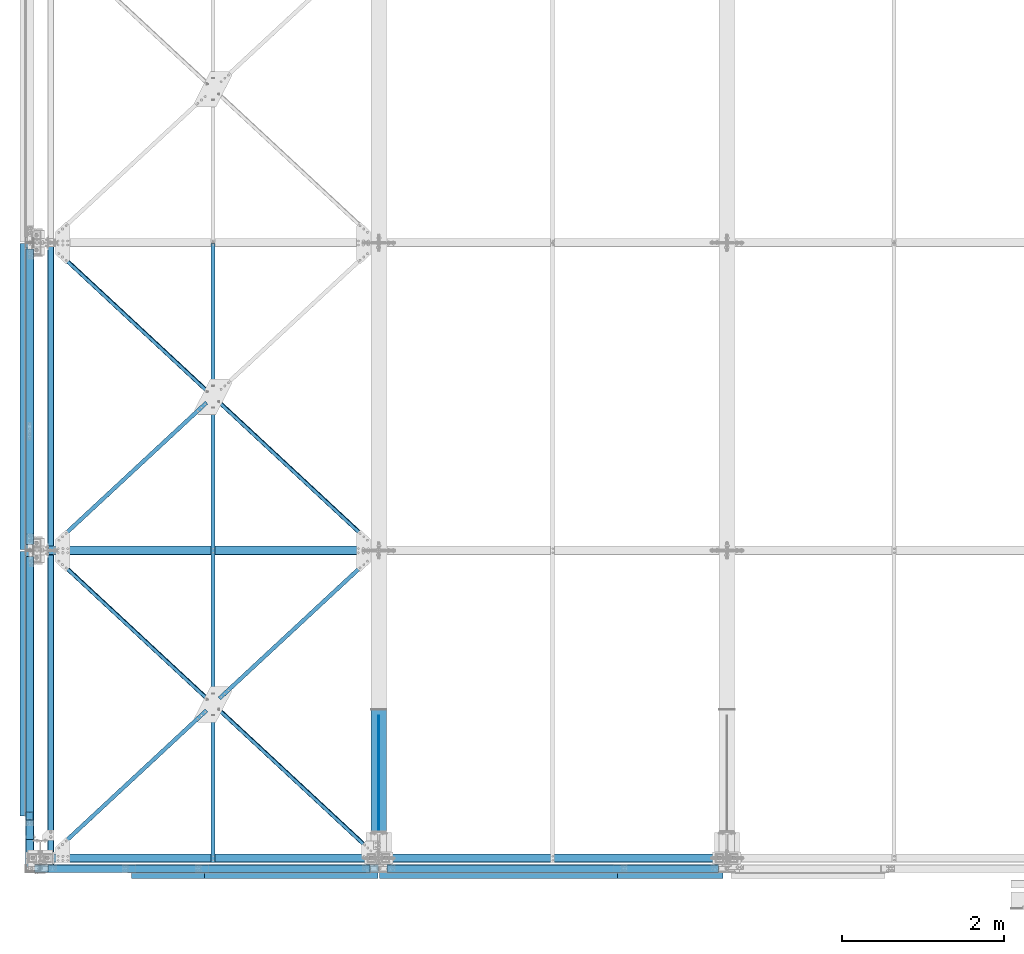
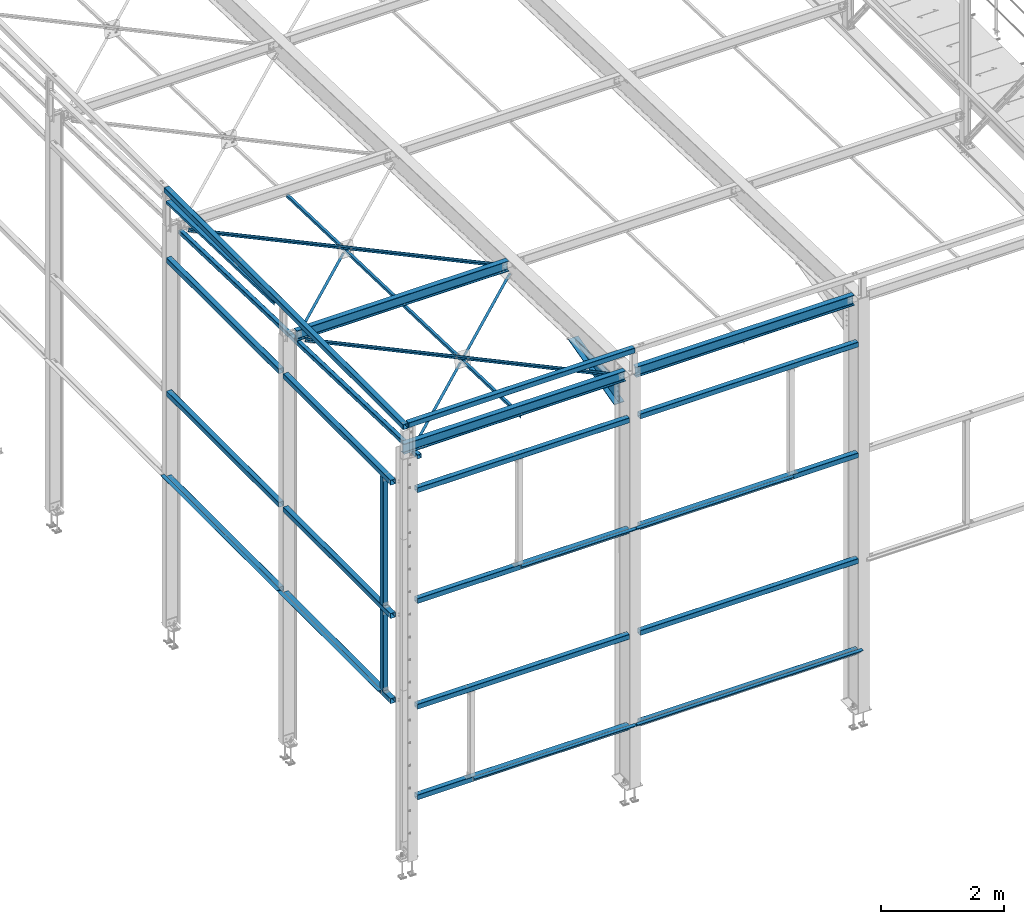
# One storey, part 41 of 496: 37 beams, 30 elements without a shape of their own.
"""IFC2X3 building model written with IfcOpenShell, lengths in millimetres."""

from ifc_helpers import new_model, si_unit, frame, origin_with_axes, origin_2d_with_axis, place, context, subcontext, project, spatial, polyline, rectangle, hollow_rectangle, i_section, l_section, u_section, outline, extrude, clip, halfspace, material, type_object, element, aggregate, save


model = new_model("IFC2X3")

# Units and contexts
model_context = context("Model", 3, precision=1e-05, world=origin_with_axes())
body_context = subcontext(model_context, "Body", "Model", "MODEL_VIEW")
ifc_project = project(units=[si_unit("LENGTHUNIT", "METRE", prefix="MILLI"), si_unit("AREAUNIT", "SQUARE_METRE"), si_unit("VOLUMEUNIT", "CUBIC_METRE"), si_unit("MASSUNIT", "GRAM", prefix="KILO"), si_unit("TIMEUNIT", "SECOND"), si_unit("PLANEANGLEUNIT", "RADIAN"), si_unit("SOLIDANGLEUNIT", "STERADIAN"), si_unit("THERMODYNAMICTEMPERATUREUNIT", "DEGREE_CELSIUS"), si_unit("LUMINOUSINTENSITYUNIT", "LUMEN")], contexts=[model_context])

# Site, building, storey
site_placement = place(None, origin_with_axes())
site = spatial("IfcSite", under=ifc_project, at=site_placement, CompositionType="ELEMENT")
building_placement = place(site_placement, origin_with_axes())
building = spatial("IfcBuilding", under=site, at=building_placement, Name="Undefined", CompositionType="ELEMENT")
storey_placement = place(building_placement, origin_with_axes())
storey = spatial("IfcBuildingStorey", under=building, at=storey_placement, Name="Undefined", CompositionType="ELEMENT", Elevation=0.0)

# Assembly, beam
assembly_1_placement = place(storey_placement, origin_with_axes())
assembly_1 = element("IfcElementAssembly", 1, at=assembly_1_placement, inside=storey, AssemblyPlace="NOTDEFINED", PredefinedType="NOTDEFINED")
ifc_material_1 = material(Name="Undefined/S235-E24")
beam_type_1 = type_object("IfcBeamType", PredefinedType="NOTDEFINED")
beam_1_placement = place(assembly_1_placement, frame((2132.95777562896, 1898.08608063122, 7759.23296372596), z_axis=(0.680838347690318, -0.732072290870568, 0.0230066349959325), x_axis=(0.732433713070062, 0.680502369065094, -0.0213864830020458)))
beam_1 = element("IfcBeam", 2, at=beam_1_placement, type_object=beam_type_1, material=ifc_material_1, context=body_context, shape_type="Clipping", body=[
    clip(clip(extrude(l_section(Depth=50.0, Width=50.0, Thickness=5.0, FilletRadius=7.0, EdgeRadius=3.5, at=origin_2d_with_axis()), frame((2792.06114197264, 9.68690801868511e-15, -2.64775642512471e-13), z_axis=(-1.0, 0.0, 0.0), x_axis=(0.0, -1.0, 0.0)), (0.0, 0.0, 1.0), 2736.72), halfspace(frame((2629.60111589512, 24.9999928826783, 24.9999858812455), z_axis=(1.0, 0.0, 0.0), x_axis=(0.0, 0.0, -1.0)), False)), halfspace(frame((106.894615057048, 31.0093179303303, 24.9999999768324), z_axis=(1.0, 0.0, 0.0), x_axis=(0.0, 1.0, 0.0)), True)),
])
aggregate(assembly_1, [beam_1])

assembly_2_placement = place(storey_placement, origin_with_axes())
assembly_2 = element("IfcElementAssembly", 3, at=assembly_2_placement, inside=storey, AssemblyPlace="NOTDEFINED", PredefinedType="NOTDEFINED")
beam_2_placement = place(assembly_2_placement, frame((2132.00001266682, -53.9015129067157, 7826.58977123071), z_axis=(1.0, 0.0, 0.0), x_axis=(0.0, 0.999506556345274, -0.0314108870109058)))
beam_2 = element("IfcBeam", 4, at=beam_2_placement, type_object=beam_type_1, material=ifc_material_1, context=body_context, shape_type="SweptSolid", body=[
    extrude(l_section(Depth=50.0, Width=50.0, Thickness=5.0, FilletRadius=7.0, EdgeRadius=3.5, at=origin_2d_with_axis()), frame((7648.75199419146, 0.0, 0.0), z_axis=(-1.0, 0.0, 0.0), x_axis=(0.0, -1.0, 0.0)), (0.0, 0.0, 1.0), 7648.75),
])
aggregate(assembly_2, [beam_2])

assembly_3_placement = place(storey_placement, origin_with_axes())
assembly_3 = element("IfcElementAssembly", 5, at=assembly_3_placement, inside=storey, AssemblyPlace="NOTDEFINED", PredefinedType="NOTDEFINED")
beam_3_placement = place(assembly_3_placement, frame((4182.04253757987, 3799.8493937089, 7755.49482368022), z_axis=(-0.680836493276887, -0.73207405927444, 0.023005242008624), x_axis=(-0.732435437033485, 0.680500574031111, -0.0213845580009777)))
beam_3 = element("IfcBeam", 6, at=beam_3_placement, type_object=beam_type_1, material=ifc_material_1, context=body_context, shape_type="Clipping", body=[
    clip(clip(extrude(l_section(Depth=50.0, Width=50.0, Thickness=5.0, FilletRadius=7.0, EdgeRadius=3.5, at=origin_2d_with_axis()), frame((5584.10997520641, -9.09494701772928e-13, 2.93028321659412e-13), z_axis=(-1.0, 0.0, 0.0), x_axis=(0.0, -1.0, 0.0)), (0.0, 0.0, 1.0), 5584.11), halfspace(frame((5421.64660010542, -25.0000571690553, -24.9999999506545), z_axis=(0.999999999997803, 2.09200000135276e-06, 1.31999999817392e-07), x_axis=(0.0, 0.0, 1.0)), False)), halfspace(frame((162.459932662962, 25.000057158848, -24.9999999867432), z_axis=(-0.999999999998359, -1.34631977040632e-06, 1.21235578021343e-06), x_axis=(1.21235578011417e-06, 7.45476427527536e-11, 0.999999999999265)), False)),
])
aggregate(assembly_3, [beam_3])

assembly_4_placement = place(storey_placement, origin_with_axes())
assembly_4 = element("IfcElementAssembly", 7, at=assembly_4_placement, inside=storey, AssemblyPlace="NOTDEFINED", PredefinedType="NOTDEFINED")
beam_4_placement = place(assembly_4_placement, frame((87.9574898072951, 3798.09030455743, 7699.52059346457), z_axis=(0.68083649638077, -0.732074010915111, 0.0230066889973314), x_axis=(0.732435434147601, 0.680500577137136, -0.0213845580043096)))
beam_4 = element("IfcBeam", 8, at=beam_4_placement, type_object=beam_type_1, material=ifc_material_1, context=body_context, shape_type="Clipping", body=[
    clip(clip(extrude(l_section(Depth=50.0, Width=50.0, Thickness=5.0, FilletRadius=7.0, EdgeRadius=3.5, at=origin_2d_with_axis()), frame((2736.71023834624, 8.99999830778118e-13, 4.62758648288336e-13), z_axis=(-1.0, 0.0, 0.0), x_axis=(0.0, -1.0, 0.0)), (0.0, 0.0, 1.0), 2736.71), halfspace(frame((162.463400706135, -25.0000933849551, 24.9999638658524), z_axis=(-0.999999999997803, 2.09199999990344e-06, -1.31999999818056e-07), x_axis=(-6.7626569939636e-10, 1.60677807515351e-06, -0.999999999998709)), False)), halfspace(frame((2685.15740098178, 31.0071053170741, 25.0000000625241), z_axis=(0.999999999998558, -1.69800000185205e-06, 0.0), x_axis=(1.69800000215235e-06, 0.999999999998558, 0.0)), False)),
])
aggregate(assembly_4, [beam_4])

assembly_5_placement = place(storey_placement, origin_with_axes())
assembly_5 = element("IfcElementAssembly", 9, at=assembly_5_placement, inside=storey, Name="Steel Assembly", AssemblyPlace="NOTDEFINED", PredefinedType="RIGID_FRAME")
ifc_material_2 = material(Name="STEEL/S235 --------------")
beam_5_placement = place(assembly_5_placement, frame((4182.04254313058, -0.159569882216601, 7874.91957929736), z_axis=(-0.680838342539438, -0.732071528315557, 0.0230310390099157), x_axis=(-0.732433717864216, 0.680502363873844, -0.0213864839960353)))
beam_5 = element("IfcBeam", 10, at=beam_5_placement, type_object=beam_type_1, material=ifc_material_2, context=body_context, shape_type="Clipping", body=[
    clip(clip(clip(extrude(l_section(Depth=50.0, Width=50.0, Thickness=5.0, FilletRadius=7.0, EdgeRadius=3.5, at=origin_2d_with_axis()), frame((5584.12307962439, 0.0, -2.75471486033162e-13), z_axis=(-1.0, 0.0, 0.0), x_axis=(0.0, -1.0, 0.0)), (0.0, 0.0, 1.0), 5584.12), halfspace(frame((107.352082511449, 24.9862130141391, -25.0000102419372), z_axis=(-0.999999746430007, -0.000712137375843514, -5.28847746923189e-07), x_axis=(0.0, 0.0, 1.0)), False)), halfspace(frame((3008.74022592529, 25.0624927776262, 2620.77401555206), z_axis=(0.0729183020569199, 2.43126534266734e-05, 0.997337916973997), x_axis=(3.85183070646305e-08, -0.999999999702936, 2.4374732290997e-05)), False)), halfspace(frame((5421.65924635987, -25.0005741456234, -24.9994035720497), z_axis=(1.0, 0.0, 0.0), x_axis=(7.20592651988103e-11, 2.38537934808418e-05, 0.999999999715498)), False)),
])
aggregate(assembly_5, [beam_5])

assembly_6_placement = place(storey_placement, origin_with_axes())
assembly_6 = element("IfcElementAssembly", 11, at=assembly_6_placement, inside=storey, AssemblyPlace="NOTDEFINED", PredefinedType="NOTDEFINED")
beam_6_placement = place(assembly_6_placement, frame((87.9574849970008, -1.91868095844802, 7818.94534983953), z_axis=(0.680838347690318, -0.732072290870568, 0.0230066349959325), x_axis=(0.732433713070062, 0.680502369065094, -0.0213864830020458)))
beam_6 = element("IfcBeam", 12, at=beam_6_placement, type_object=beam_type_1, material=ifc_material_1, context=body_context, shape_type="Clipping", body=[
    clip(clip(extrude(l_section(Depth=50.0, Width=50.0, Thickness=5.0, FilletRadius=7.0, EdgeRadius=3.5, at=origin_2d_with_axis()), frame((2736.72033254361, -9.09494701772928e-13, 9.38252055267922e-14), z_axis=(-1.0, 0.0, 0.0), x_axis=(0.0, -1.0, 0.0)), (0.0, 0.0, 1.0), 2736.72), halfspace(frame((162.459973877454, 25.0000221405762, -24.9999999838102), z_axis=(-1.0, 0.0, 0.0), x_axis=(0.0, 0.0, 1.0)), False)), halfspace(frame((2685.16732033268, 31.009205449107, 25.0000000845653), z_axis=(1.0, 0.0, 0.0), x_axis=(0.0, 1.0, 0.0)), False)),
])
aggregate(assembly_6, [beam_6])

assembly_7_placement = place(storey_placement, origin_with_axes())
assembly_7 = element("IfcElementAssembly", 13, at=assembly_7_placement, inside=storey, Name="LISSE", AssemblyPlace="NOTDEFINED", PredefinedType="NOTDEFINED")
beam_type_2 = type_object("IfcBeamType", PredefinedType="NOTDEFINED")
beam_7_placement = place(assembly_7_placement, frame((-129.999999999254, 3799.99999997022, 8410.85601504986), z_axis=(1.0, 0.0, 0.0), x_axis=(0.0, 0.999506445341009, -0.0314144190107172)))
beam_7 = element("IfcBeam", 14, at=beam_7_placement, type_object=beam_type_2, material=ifc_material_1, Name="LISSE", context=body_context, shape_type="Clipping", body=[
    clip(clip(extrude(u_section(Depth=100.0, FlangeWidth=50.0, WebThickness=4.0, FlangeThickness=4.0, at=origin_2d_with_axis()), frame((3738.43154409699, 2.59405798515091e-14, 0.0), z_axis=(-1.0, 0.0, 0.0), x_axis=(0.0, -1.0, 0.0)), (0.0, 0.0, 1.0), 3536.42), halfspace(frame((3735.73414698921, 35.3226290313178, 49.9999999992579), z_axis=(-0.999506472307554, -0.0314135610096736, 0.0), x_axis=(0.0, 0.0, 1.0)), True)), halfspace(frame((202.484021196273, 35.5224298009161, 49.9999999992579), z_axis=(0.999506472307554, 0.0314135610096964, 0.0), x_axis=(0.0, 0.0, 1.0)), True)),
])
aggregate(assembly_7, [beam_7])

assembly_8_placement = place(storey_placement, origin_with_axes())
assembly_8 = element("IfcElementAssembly", 15, at=assembly_8_placement, inside=storey, Name="MONTANT", AssemblyPlace="NOTDEFINED", PredefinedType="NOTDEFINED")
beam_type_3 = type_object("IfcBeamType", PredefinedType="NOTDEFINED")
beam_8_placement = place(assembly_8_placement, frame((-129.999916880554, 519.993382399492, 4445.00002208328), z_axis=(1.0, 0.0, 0.0), x_axis=(0.0, 0.0, -1.0)))
beam_8 = element("IfcBeam", 16, at=beam_8_placement, type_object=beam_type_3, material=ifc_material_1, Name="MONTANT", context=body_context, shape_type="SweptSolid", body=[
    extrude(hollow_rectangle(XDim=100.0, YDim=100.0, WallThickness=4.0, InnerFilletRadius=4.0, OuterFilletRadius=8.0, at=origin_2d_with_axis()), frame((1580.00002213783, -3.26736346536441e-22, 0.0), z_axis=(-1.0, 0.0, 0.0), x_axis=(0.0, -1.0, 0.0)), (0.0, 0.0, 1.0), 1580.0),
])
aggregate(assembly_8, [beam_8])

assembly_9_placement = place(storey_placement, origin_with_axes())
assembly_9 = element("IfcElementAssembly", 17, at=assembly_9_placement, inside=storey, Name="LISSE", AssemblyPlace="NOTDEFINED", PredefinedType="NOTDEFINED")
beam_9_placement = place(assembly_9_placement, frame((-129.999999891005, 7595.00000002971, 8500.00000001911), z_axis=(0.0, 0.0, 1.0), x_axis=(0.0, -1.0, 0.0)))
beam_9 = element("IfcBeam", 18, at=beam_9_placement, type_object=beam_type_3, material=ifc_material_1, Name="LISSE", context=body_context, shape_type="SweptSolid", body=[
    extrude(hollow_rectangle(XDim=100.0, YDim=100.0, WallThickness=4.0, InnerFilletRadius=4.0, OuterFilletRadius=8.0, at=origin_2d_with_axis()), frame((7775.00000003686, 0.0, 0.0), z_axis=(-1.0, 0.0, 0.0), x_axis=(0.0, -1.0, 0.0)), (0.0, 0.0, 1.0), 7775.0),
])
aggregate(assembly_9, [beam_9])

assembly_10_placement = place(storey_placement, origin_with_axes())
assembly_10 = element("IfcElementAssembly", 19, at=assembly_10_placement, inside=storey, Name="LISSE", AssemblyPlace="NOTDEFINED", PredefinedType="NOTDEFINED")
beam_10_placement = place(assembly_10_placement, frame((-130.000001390422, 3724.99999092642, 4500.0), z_axis=(0.0, 0.0, 1.0), x_axis=(0.0, -1.0, 0.0)))
beam_10 = element("IfcBeam", 20, at=beam_10_placement, type_object=beam_type_3, material=ifc_material_1, Name="LISSE", context=body_context, shape_type="SweptSolid", body=[
    extrude(hollow_rectangle(XDim=100.0, YDim=100.0, WallThickness=4.0, InnerFilletRadius=4.0, OuterFilletRadius=8.0, at=origin_2d_with_axis()), frame((3494.99999900398, 0.0, 0.0), z_axis=(-1.0, 0.0, 0.0), x_axis=(0.0, -1.0, 0.0)), (0.0, 0.0, 1.0), 3495.0),
])
aggregate(assembly_10, [beam_10])

assembly_11_placement = place(storey_placement, origin_with_axes())
assembly_11 = element("IfcElementAssembly", 21, at=assembly_11_placement, inside=storey, Name="LISSE", AssemblyPlace="NOTDEFINED", PredefinedType="NOTDEFINED")
beam_11_placement = place(assembly_11_placement, frame((-129.999999652064, 7524.99999131917, 4500.00000022511), z_axis=(0.0, 0.0, 1.0), x_axis=(0.0, -1.0, 0.0)))
beam_11 = element("IfcBeam", 22, at=beam_11_placement, type_object=beam_type_3, material=ifc_material_1, Name="LISSE", context=body_context, shape_type="SweptSolid", body=[
    extrude(hollow_rectangle(XDim=100.0, YDim=100.0, WallThickness=4.0, InnerFilletRadius=4.0, OuterFilletRadius=8.0, at=origin_2d_with_axis()), frame((3650.0, 0.0, 0.0), z_axis=(-1.0, 0.0, 0.0), x_axis=(0.0, -1.0, 0.0)), (0.0, 0.0, 1.0), 3650.0),
])
aggregate(assembly_11, [beam_11])

assembly_12_placement = place(storey_placement, origin_with_axes())
assembly_12 = element("IfcElementAssembly", 23, at=assembly_12_placement, inside=storey, Name="LISSE", AssemblyPlace="NOTDEFINED", PredefinedType="NOTDEFINED")
beam_12_placement = place(assembly_12_placement, frame((4285.0000000001, -130.000008279542, 7150.0), z_axis=(0.0, 0.0, -1.0), x_axis=(1.0, 0.0, 0.0)))
beam_12 = element("IfcBeam", 24, at=beam_12_placement, type_object=beam_type_3, material=ifc_material_1, Name="LISSE", context=body_context, shape_type="SweptSolid", body=[
    extrude(hollow_rectangle(XDim=100.0, YDim=100.0, WallThickness=4.0, InnerFilletRadius=4.0, OuterFilletRadius=8.0, at=origin_2d_with_axis()), frame((4089.9999999999, 0.0, 0.0), z_axis=(-1.0, 0.0, 0.0), x_axis=(0.0, -1.0, 0.0)), (0.0, 0.0, 1.0), 4090.0),
])
aggregate(assembly_12, [beam_12])

assembly_13_placement = place(storey_placement, origin_with_axes())
assembly_13 = element("IfcElementAssembly", 25, at=assembly_13_placement, inside=storey, Name="LISSE", AssemblyPlace="NOTDEFINED", PredefinedType="NOTDEFINED")
beam_13_placement = place(assembly_13_placement, frame((4285.0, -130.000008279766, 4949.99999999904), z_axis=(0.0, 0.0, 1.0), x_axis=(1.0, 0.0, 0.0)))
beam_13 = element("IfcBeam", 26, at=beam_13_placement, type_object=beam_type_3, material=ifc_material_1, Name="LISSE", context=body_context, shape_type="SweptSolid", body=[
    extrude(hollow_rectangle(XDim=100.0, YDim=100.0, WallThickness=4.0, InnerFilletRadius=4.0, OuterFilletRadius=8.0, at=origin_2d_with_axis()), frame((4089.9999999999, 0.0, 0.0), z_axis=(-1.0, 0.0, 0.0), x_axis=(0.0, -1.0, 0.0)), (0.0, 0.0, 1.0), 4090.0),
])

assembly_14_placement = place(storey_placement, origin_with_axes())
assembly_14 = element("IfcElementAssembly", 27, at=assembly_14_placement, inside=storey, Name="LISSE", AssemblyPlace="NOTDEFINED", PredefinedType="NOTDEFINED")
beam_14_placement = place(assembly_14_placement, frame((4284.99999999743, -130.000008283344, 2850.0), z_axis=(0.0, 0.0, -1.0), x_axis=(1.0, 0.0, 0.0)))
beam_14 = element("IfcBeam", 28, at=beam_14_placement, type_object=beam_type_3, material=ifc_material_1, Name="LISSE", context=body_context, shape_type="SweptSolid", body=[
    extrude(hollow_rectangle(XDim=100.0, YDim=100.0, WallThickness=4.0, InnerFilletRadius=4.0, OuterFilletRadius=8.0, at=origin_2d_with_axis()), frame((4089.9999999999, 0.0, 0.0), z_axis=(-1.0, 0.0, 0.0), x_axis=(0.0, -1.0, 0.0)), (0.0, 0.0, 1.0), 4090.0),
])
aggregate(assembly_14, [beam_14])

assembly_15_placement = place(storey_placement, origin_with_axes())
assembly_15 = element("IfcElementAssembly", 29, at=assembly_15_placement, inside=storey, Name="LISSE", AssemblyPlace="NOTDEFINED", PredefinedType="NOTDEFINED")
beam_15_placement = place(assembly_15_placement, frame((4285.00000000001, -130.000008279691, 1049.99999999904), z_axis=(0.0, 0.0, 1.0), x_axis=(1.0, 0.0, 0.0)))
beam_15 = element("IfcBeam", 30, at=beam_15_placement, type_object=beam_type_3, material=ifc_material_1, Name="LISSE", context=body_context, shape_type="SweptSolid", body=[
    extrude(hollow_rectangle(XDim=100.0, YDim=100.0, WallThickness=4.0, InnerFilletRadius=4.0, OuterFilletRadius=8.0, at=origin_2d_with_axis()), frame((4089.9999999999, 0.0, 0.0), z_axis=(-1.0, 0.0, 0.0), x_axis=(0.0, -1.0, 0.0)), (0.0, 0.0, 1.0), 4090.0),
])

assembly_16_placement = place(storey_placement, origin_with_axes())
assembly_16 = element("IfcElementAssembly", 31, at=assembly_16_placement, inside=storey, Name="LISSE", AssemblyPlace="NOTDEFINED", PredefinedType="NOTDEFINED")
beam_16_placement = place(assembly_16_placement, frame((95.0000000074225, -130.000007684713, 7150.0), z_axis=(0.0, 0.0, -1.0), x_axis=(1.0, 0.0, 0.0)))
beam_16 = element("IfcBeam", 32, at=beam_16_placement, type_object=beam_type_3, material=ifc_material_1, Name="LISSE", context=body_context, shape_type="SweptSolid", body=[
    extrude(hollow_rectangle(XDim=100.0, YDim=100.0, WallThickness=4.0, InnerFilletRadius=4.0, OuterFilletRadius=8.0, at=origin_2d_with_axis()), frame((3980.00000000009, 0.0, 0.0), z_axis=(-1.0, 0.0, 0.0), x_axis=(0.0, -1.0, 0.0)), (0.0, 0.0, 1.0), 3980.0),
])
aggregate(assembly_16, [beam_16])

assembly_17_placement = place(storey_placement, origin_with_axes())
assembly_17 = element("IfcElementAssembly", 33, at=assembly_17_placement, inside=storey, Name="LISSE", AssemblyPlace="NOTDEFINED", PredefinedType="NOTDEFINED")
beam_17_placement = place(assembly_17_placement, frame((95.0000000074318, -130.000007684151, 4949.99999999904), z_axis=(0.0, 0.0, 1.0), x_axis=(1.0, 0.0, 0.0)))
beam_17 = element("IfcBeam", 34, at=beam_17_placement, type_object=beam_type_3, material=ifc_material_1, Name="LISSE", context=body_context, shape_type="SweptSolid", body=[
    extrude(hollow_rectangle(XDim=100.0, YDim=100.0, WallThickness=4.0, InnerFilletRadius=4.0, OuterFilletRadius=8.0, at=origin_2d_with_axis()), frame((3980.00000000009, 0.0, 0.0), z_axis=(-1.0, 0.0, 0.0), x_axis=(0.0, -1.0, 0.0)), (0.0, 0.0, 1.0), 3980.0),
])

assembly_18_placement = place(storey_placement, origin_with_axes())
assembly_18 = element("IfcElementAssembly", 35, at=assembly_18_placement, inside=storey, Name="LISSE", AssemblyPlace="NOTDEFINED", PredefinedType="NOTDEFINED")
beam_18_placement = place(assembly_18_placement, frame((95.0000000074201, -130.000007684626, 2850.0), z_axis=(0.0, 0.0, -1.0), x_axis=(1.0, 0.0, 0.0)))
beam_18 = element("IfcBeam", 36, at=beam_18_placement, type_object=beam_type_3, material=ifc_material_1, Name="LISSE", context=body_context, shape_type="SweptSolid", body=[
    extrude(hollow_rectangle(XDim=100.0, YDim=100.0, WallThickness=4.0, InnerFilletRadius=4.0, OuterFilletRadius=8.0, at=origin_2d_with_axis()), frame((3980.00000000009, 0.0, 0.0), z_axis=(-1.0, 0.0, 0.0), x_axis=(0.0, -1.0, 0.0)), (0.0, 0.0, 1.0), 3980.0),
])
aggregate(assembly_18, [beam_18])

assembly_19_placement = place(storey_placement, origin_with_axes())
assembly_19 = element("IfcElementAssembly", 37, at=assembly_19_placement, inside=storey, Name="LISSE", AssemblyPlace="NOTDEFINED", PredefinedType="NOTDEFINED")
beam_19_placement = place(assembly_19_placement, frame((95.0000000074324, -130.000007684076, 1049.99999999904), z_axis=(0.0, 0.0, 1.0), x_axis=(1.0, 0.0, 0.0)))
beam_19 = element("IfcBeam", 38, at=beam_19_placement, type_object=beam_type_3, material=ifc_material_1, Name="LISSE", context=body_context, shape_type="SweptSolid", body=[
    extrude(hollow_rectangle(XDim=100.0, YDim=100.0, WallThickness=4.0, InnerFilletRadius=4.0, OuterFilletRadius=8.0, at=origin_2d_with_axis()), frame((3980.00000000009, 0.0, 0.0), z_axis=(-1.0, 0.0, 0.0), x_axis=(0.0, -1.0, 0.0)), (0.0, 0.0, 1.0), 3980.0),
])

assembly_20_placement = place(storey_placement, origin_with_axes())
assembly_20 = element("IfcElementAssembly", 39, at=assembly_20_placement, inside=storey, Name="LISSE", AssemblyPlace="NOTDEFINED", PredefinedType="NOTDEFINED")
beam_20_placement = place(assembly_20_placement, frame((-129.999999646836, 7524.9999991069, 7150.00000925125), z_axis=(0.0, 0.0, -1.0), x_axis=(0.0, -1.0, 0.0)))
beam_20 = element("IfcBeam", 40, at=beam_20_placement, type_object=beam_type_3, material=ifc_material_1, Name="LISSE", context=body_context, shape_type="SweptSolid", body=[
    extrude(hollow_rectangle(XDim=100.0, YDim=100.0, WallThickness=4.0, InnerFilletRadius=4.0, OuterFilletRadius=8.0, at=origin_2d_with_axis()), frame((3650.0, 0.0, 0.0), z_axis=(-1.0, 0.0, 0.0), x_axis=(0.0, -1.0, 0.0)), (0.0, 0.0, 1.0), 3650.0),
])
aggregate(assembly_20, [beam_20])

assembly_21_placement = place(storey_placement, origin_with_axes())
assembly_21 = element("IfcElementAssembly", 41, at=assembly_21_placement, inside=storey, Name="LISSE", AssemblyPlace="NOTDEFINED", PredefinedType="NOTDEFINED")
beam_21_placement = place(assembly_21_placement, frame((-130.00000139915, 3725.0000040295, 7150.00000377003), z_axis=(0.0, 0.0, -1.0), x_axis=(0.0, -1.0, 0.0)))
beam_21 = element("IfcBeam", 42, at=beam_21_placement, type_object=beam_type_3, material=ifc_material_1, Name="LISSE", context=body_context, shape_type="SweptSolid", body=[
    extrude(hollow_rectangle(XDim=100.0, YDim=100.0, WallThickness=4.0, InnerFilletRadius=4.0, OuterFilletRadius=8.0, at=origin_2d_with_axis()), frame((3494.99999900398, 0.0, 0.0), z_axis=(-1.0, 0.0, 0.0), x_axis=(0.0, -1.0, 0.0)), (0.0, 0.0, 1.0), 3495.0),
])
aggregate(assembly_21, [beam_21])

assembly_22_placement = place(storey_placement, origin_with_axes())
assembly_22 = element("IfcElementAssembly", 43, at=assembly_22_placement, inside=storey, Name="LISSE", AssemblyPlace="NOTDEFINED", PredefinedType="NOTDEFINED")
beam_22_placement = place(assembly_22_placement, frame((-130.000001390422, 3724.99999861062, 2809.99999988523), z_axis=(0.0, 0.0, 1.0), x_axis=(0.0, -1.0, 0.0)))
beam_22 = element("IfcBeam", 44, at=beam_22_placement, type_object=beam_type_3, material=ifc_material_1, Name="LISSE", context=body_context, shape_type="SweptSolid", body=[
    extrude(hollow_rectangle(XDim=100.0, YDim=100.0, WallThickness=4.0, InnerFilletRadius=4.0, OuterFilletRadius=8.0, at=origin_2d_with_axis()), frame((3494.99999900398, 0.0, 0.0), z_axis=(-1.0, 0.0, 0.0), x_axis=(0.0, -1.0, 0.0)), (0.0, 0.0, 1.0), 3495.0),
])

assembly_23_placement = place(storey_placement, origin_with_axes())
assembly_23 = element("IfcElementAssembly", 45, at=assembly_23_placement, inside=storey, Name="LISSE", AssemblyPlace="NOTDEFINED", PredefinedType="NOTDEFINED")
beam_23_placement = place(assembly_23_placement, frame((-129.999999652064, 7524.99999900332, 2810.00000011033), z_axis=(0.0, 0.0, 1.0), x_axis=(0.0, -1.0, 0.0)))
beam_23 = element("IfcBeam", 46, at=beam_23_placement, type_object=beam_type_3, material=ifc_material_1, Name="LISSE", context=body_context, shape_type="SweptSolid", body=[
    extrude(hollow_rectangle(XDim=100.0, YDim=100.0, WallThickness=4.0, InnerFilletRadius=4.0, OuterFilletRadius=8.0, at=origin_2d_with_axis()), frame((3650.0, 0.0, 0.0), z_axis=(-1.0, 0.0, 0.0), x_axis=(0.0, -1.0, 0.0)), (0.0, 0.0, 1.0), 3650.0),
])

assembly_24_placement = place(storey_placement, origin_with_axes())
assembly_24 = element("IfcElementAssembly", 47, at=assembly_24_placement, inside=storey, Name="MONTANT", AssemblyPlace="NOTDEFINED", PredefinedType="NOTDEFINED")
beam_24_placement = place(assembly_24_placement, frame((-129.999916873212, 519.993384643543, 7095.00000856518), z_axis=(1.0, 0.0, 0.0), x_axis=(0.0, 0.0, -1.0)))
beam_24 = element("IfcBeam", 48, at=beam_24_placement, type_object=beam_type_3, material=ifc_material_1, Name="MONTANT", context=body_context, shape_type="SweptSolid", body=[
    extrude(hollow_rectangle(XDim=100.0, YDim=100.0, WallThickness=4.0, InnerFilletRadius=4.0, OuterFilletRadius=8.0, at=origin_2d_with_axis()), frame((2539.99998650413, 0.0, 0.0), z_axis=(-1.0, 0.0, 0.0), x_axis=(0.0, -1.0, 0.0)), (0.0, 0.0, 1.0), 2540.0),
])
aggregate(assembly_24, [beam_24])

assembly_25_placement = place(storey_placement, origin_with_axes())
assembly_25 = element("IfcElementAssembly", 49, at=assembly_25_placement, inside=storey, Name="LISSE", AssemblyPlace="NOTDEFINED", PredefinedType="NOTDEFINED")
beam_25_placement = place(assembly_25_placement, frame((-70.0, -130.0, 8500.0), z_axis=(0.0, 0.0, 1.0), x_axis=(1.0, 0.0, 0.0)))
beam_25 = element("IfcBeam", 50, at=beam_25_placement, type_object=beam_type_3, material=ifc_material_1, Name="LISSE", context=body_context, shape_type="SweptSolid", body=[
    extrude(hollow_rectangle(XDim=100.0, YDim=100.0, WallThickness=4.0, InnerFilletRadius=4.0, OuterFilletRadius=8.0, at=origin_2d_with_axis()), frame((4245.0, 0.0, 0.0), z_axis=(-1.0, 0.0, 0.0), x_axis=(0.0, -1.0, 0.0)), (0.0, 0.0, 1.0), 4245.0),
])
aggregate(assembly_25, [beam_25])

# Beam
beam_type_4 = type_object("IfcBeamType", PredefinedType="NOTDEFINED")
beam_26_placement = place(assembly_13_placement, frame((4190.0, -215.000007684151, 4965.0), z_axis=(0.0, -1.0, 0.0), x_axis=(1.0, 0.0, 0.0)))
beam_26 = element("IfcBeam", 51, at=beam_26_placement, type_object=beam_type_4, material=ifc_material_1, Name="SUPPORT", context=body_context, shape_type="SweptSolid", body=[
    extrude(l_section(Depth=70.0, Width=70.0, Thickness=7.0, FilletRadius=9.0, EdgeRadius=4.5, at=origin_2d_with_axis()), frame((2940.0025831881, 0.0, 0.0), z_axis=(-1.0, 0.0, 0.0), x_axis=(0.0, -1.0, 0.0)), (0.0, 0.0, 1.0), 2940.0),
])

aggregate(assembly_13, [beam_26, beam_13])

beam_27_placement = place(assembly_15_placement, frame((4190.0, -215.000007684151, 1065.0), z_axis=(0.0, -1.0, 0.0), x_axis=(1.0, 0.0, 0.0)))
beam_27 = element("IfcBeam", 52, at=beam_27_placement, type_object=beam_type_4, material=ifc_material_1, Name="SUPPORT", context=body_context, shape_type="SweptSolid", body=[
    extrude(l_section(Depth=70.0, Width=70.0, Thickness=7.0, FilletRadius=9.0, EdgeRadius=4.5, at=origin_2d_with_axis()), frame((4239.99781571392, 0.0, 0.0), z_axis=(-1.0, 0.0, 0.0), x_axis=(0.0, -1.0, 0.0)), (0.0, 0.0, 1.0), 4240.0),
])

aggregate(assembly_15, [beam_27, beam_15])

beam_28_placement = place(assembly_19_placement, frame((1130.0, -215.000007684151, 1065.0), z_axis=(0.0, -1.0, 0.0), x_axis=(1.0, 0.0, 0.0)))
beam_28 = element("IfcBeam", 53, at=beam_28_placement, type_object=beam_type_4, material=ifc_material_1, Name="SUPPORT", context=body_context, shape_type="SweptSolid", body=[
    extrude(l_section(Depth=70.0, Width=70.0, Thickness=7.0, FilletRadius=9.0, EdgeRadius=4.5, at=origin_2d_with_axis()), frame((3040.0, 0.0, 0.0), z_axis=(-1.0, 0.0, 0.0), x_axis=(0.0, -1.0, 0.0)), (0.0, 0.0, 1.0), 3040.0),
])

aggregate(assembly_19, [beam_28, beam_19])

beam_29_placement = place(assembly_17_placement, frame((2029.99476747419, -215.000007684151, 4965.0), z_axis=(0.0, -1.0, 0.0), x_axis=(1.0, 0.0, 0.0)))
beam_29 = element("IfcBeam", 54, at=beam_29_placement, type_object=beam_type_4, material=ifc_material_1, Name="SUPPORT", context=body_context, shape_type="SweptSolid", body=[
    extrude(l_section(Depth=70.0, Width=70.0, Thickness=7.0, FilletRadius=9.0, EdgeRadius=4.5, at=origin_2d_with_axis()), frame((2140.00523252582, 0.0, 0.0), z_axis=(-1.0, 0.0, 0.0), x_axis=(0.0, -1.0, 0.0)), (0.0, 0.0, 1.0), 2140.01),
])

aggregate(assembly_17, [beam_29, beam_17])

beam_30_placement = place(assembly_23_placement, frame((-215.000001390421, 7589.99999792678, 2824.99999059685), z_axis=(-1.0, 0.0, 0.0), x_axis=(0.0, -1.0, 0.0)))
beam_30 = element("IfcBeam", 55, at=beam_30_placement, type_object=beam_type_4, material=ifc_material_1, Name="LISSE", context=body_context, shape_type="SweptSolid", body=[
    extrude(l_section(Depth=70.0, Width=70.0, Thickness=7.0, FilletRadius=9.0, EdgeRadius=4.5, at=origin_2d_with_axis()), frame((3779.99999902119, 1.5633713573204e-21, 0.0), z_axis=(-1.0, 0.0, 0.0), x_axis=(0.0, -1.0, 0.0)), (0.0, 0.0, 1.0), 3780.0),
])

aggregate(assembly_23, [beam_30, beam_23])

beam_31_placement = place(assembly_22_placement, frame((-215.000001390421, 3789.99999864029, 2824.99999052871), z_axis=(-1.0, 0.0, 0.0), x_axis=(0.0, -1.0, 0.0)))
beam_31 = element("IfcBeam", 56, at=beam_31_placement, type_object=beam_type_4, material=ifc_material_1, Name="LISSE", context=body_context, shape_type="SweptSolid", body=[
    extrude(l_section(Depth=70.0, Width=70.0, Thickness=7.0, FilletRadius=9.0, EdgeRadius=4.5, at=origin_2d_with_axis()), frame((3270.00999900399, 0.0, -4.75664309849363e-29), z_axis=(-1.0, 0.0, 0.0), x_axis=(0.0, -1.0, 0.0)), (0.0, 0.0, 1.0), 3270.01),
])

aggregate(assembly_22, [beam_31, beam_22])

# Assembly, beams
assembly_26_placement = place(storey_placement, origin_with_axes())
assembly_26 = element("IfcElementAssembly", 57, at=assembly_26_placement, inside=storey, Name="TRAVERSE", AssemblyPlace="NOTDEFINED", PredefinedType="NOTDEFINED")
beam_type_5 = type_object("IfcBeamType", PredefinedType="NOTDEFINED")
beam_32_placement = place(assembly_26_placement, frame((4180.0, 1836.15791643143, 7534.87805845615), z_axis=(1.0, 0.0, 0.0), x_axis=(0.0, -0.967446195634957, -0.253076783904507)))
beam_32 = element("IfcBeam", 58, at=beam_32_placement, type_object=beam_type_5, material=ifc_material_1, context=body_context, shape_type="SweptSolid", body=[
    extrude(rectangle(XDim=15.0, YDim=190.0, at=origin_2d_with_axis()), frame((1549.7087562475, 0.0, 0.0), z_axis=(-1.0, 0.0, 0.0), x_axis=(0.0, -1.0, 0.0)), (0.0, 0.0, 1.0), 1549.71),
])
beam_type_6 = type_object("IfcBeamType", PredefinedType="NOTDEFINED")
beam_33_placement = place(assembly_26_placement, frame((4180.0, 335.0, 7589.25004344064), z_axis=(-1.0, 0.0, 0.0), x_axis=(0.0, 0.999506556345274, -0.0314108870109058)))
beam_33 = element("IfcBeam", 59, at=beam_33_placement, type_object=beam_type_6, material=ifc_material_1, context=body_context, shape_type="SweptSolid", body=[
    extrude(outline(polyline([(0.942322762899387, 29.9851968112687), (30.0, 0.0), (1419.99999999984, -1.22432538773864e-09), (1423.27844149021, 22.6672111163732), (42.569691038819, 430.594491876205), (12.856783834807, 409.109499234062), (0.942322762899387, 29.9851968112687)])), frame((0.0, 0.0, -5.0), z_axis=(0.0, 0.0, 1.0), x_axis=(1.0, 0.0, 0.0)), (0.0, 0.0, 1.0), 10.0),
])
aggregate(assembly_26, [beam_33, beam_32])

# Assembly, beam
assembly_27_placement = place(storey_placement, origin_with_axes())
assembly_27 = element("IfcElementAssembly", 60, at=assembly_27_placement, inside=storey, AssemblyPlace="NOTDEFINED", PredefinedType="NOTDEFINED")
beam_type_7 = type_object("IfcBeamType", PredefinedType="NOTDEFINED")
beam_34_placement = place(assembly_27_placement, frame((130.000000000713, -181.256430800002, 7815.57773073848), z_axis=(0.0, -0.031410887010906, -0.999506556345274), x_axis=(0.0, 0.999506556345274, -0.0314108870109058)))
beam_34 = element("IfcBeam", 61, at=beam_34_placement, type_object=beam_type_7, material=ifc_material_1, context=body_context, shape_type="Clipping", body=[
    clip(clip(extrude(hollow_rectangle(XDim=80.0, YDim=80.0, WallThickness=4.0, InnerFilletRadius=4.0, OuterFilletRadius=8.0, at=origin_2d_with_axis()), frame((7782.63468409965, 0.0, 5.4002876365836e-14), z_axis=(-1.0, 0.0, 0.0), x_axis=(0.0, -1.0, 0.0)), (0.0, 0.0, 1.0), 7783.92), halfspace(frame((7781.5132409078, -130.000000000713, 45.1151114430941), z_axis=(-0.999506560367824, 0.0, 0.0314107590115593), x_axis=(0.0, -1.0, 0.0)), True)), halfspace(frame((-1.42554167094511, -130.000000000713, -85.3614556929715), z_axis=(0.999506560367824, 0.0, -0.0314107590115582), x_axis=(0.0, -1.0, 0.0)), True)),
])
aggregate(assembly_27, [beam_34])

assembly_28_placement = place(storey_placement, origin_with_axes())
assembly_28 = element("IfcElementAssembly", 62, at=assembly_28_placement, inside=storey, AssemblyPlace="NOTDEFINED", PredefinedType="NOTDEFINED")
ifc_material_3 = material(Name="Undefined/S275-E28")
beam_type_8 = type_object("IfcBeamType", Name="IPE200", PredefinedType="NOTDEFINED")
beam_35_placement = place(assembly_28_placement, frame((4280.0, 1.7234924598597e-09, 7949.95062448272), z_axis=(0.0, 0.031410887010906, 0.999506556345274), x_axis=(1.0, 0.0, 0.0)))
beam_35 = element("IfcBeam", 63, at=beam_35_placement, type_object=beam_type_8, material=ifc_material_3, ObjectType="IPE200", context=body_context, shape_type="SweptSolid", body=[
    extrude(i_section(OverallWidth=100.0, OverallDepth=200.0, WebThickness=5.599999905, FlangeThickness=8.5, FilletRadius=12.0, at=origin_2d_with_axis()), frame((4100.0, 0.0, 0.0), z_axis=(-1.0, 0.0, 0.0), x_axis=(0.0, -1.0, 0.0)), (0.0, 0.0, 1.0), 4100.0),
])
aggregate(assembly_28, [beam_35])

assembly_29_placement = place(storey_placement, origin_with_axes())
assembly_29 = element("IfcElementAssembly", 64, at=assembly_29_placement, inside=storey, AssemblyPlace="NOTDEFINED", PredefinedType="NOTDEFINED")
beam_36_placement = place(assembly_29_placement, frame((100.000000000018, 3800.00552192374, 7830.530621228), z_axis=(0.0, 0.031410887010906, 0.999506556345274), x_axis=(1.0, 0.0, 0.0)))
beam_36 = element("IfcBeam", 65, at=beam_36_placement, type_object=beam_type_8, material=ifc_material_3, ObjectType="IPE200", context=body_context, shape_type="SweptSolid", body=[
    extrude(i_section(OverallWidth=100.0, OverallDepth=200.0, WebThickness=5.599999905, FlangeThickness=8.5, FilletRadius=12.0, at=origin_2d_with_axis()), frame((3980.00000000009, 0.0, 0.0), z_axis=(-1.0, 0.0, 0.0), x_axis=(0.0, -1.0, 0.0)), (0.0, 0.0, 1.0), 3980.0),
])
aggregate(assembly_29, [beam_36])

assembly_30_placement = place(storey_placement, origin_with_axes())
assembly_30 = element("IfcElementAssembly", 66, at=assembly_30_placement, inside=storey, Name="Steel Assembly", AssemblyPlace="NOTDEFINED", PredefinedType="RIGID_FRAME")
ifc_material_4 = material(Name="STEEL/S235J0")
beam_37_placement = place(assembly_30_placement, frame((-84.9999999999318, -1.00084832865832e-07, 7949.95062448062), z_axis=(0.0, 0.031410887010906, 0.999506556345274), x_axis=(1.0, 0.0, 0.0)))
beam_37 = element("IfcBeam", 67, at=beam_37_placement, type_object=beam_type_8, material=ifc_material_4, ObjectType="IPE200", context=body_context, shape_type="SweptSolid", body=[
    extrude(i_section(OverallWidth=100.0, OverallDepth=200.0, WebThickness=5.599999905, FlangeThickness=8.5, FilletRadius=12.0, at=origin_2d_with_axis()), frame((4164.99999999998, 0.0, 0.0), z_axis=(-1.0, 0.0, 0.0), x_axis=(0.0, -1.0, 0.0)), (0.0, 0.0, 1.0), 4165.0),
])
aggregate(assembly_30, [beam_37])

save(model, "model.ifc")
